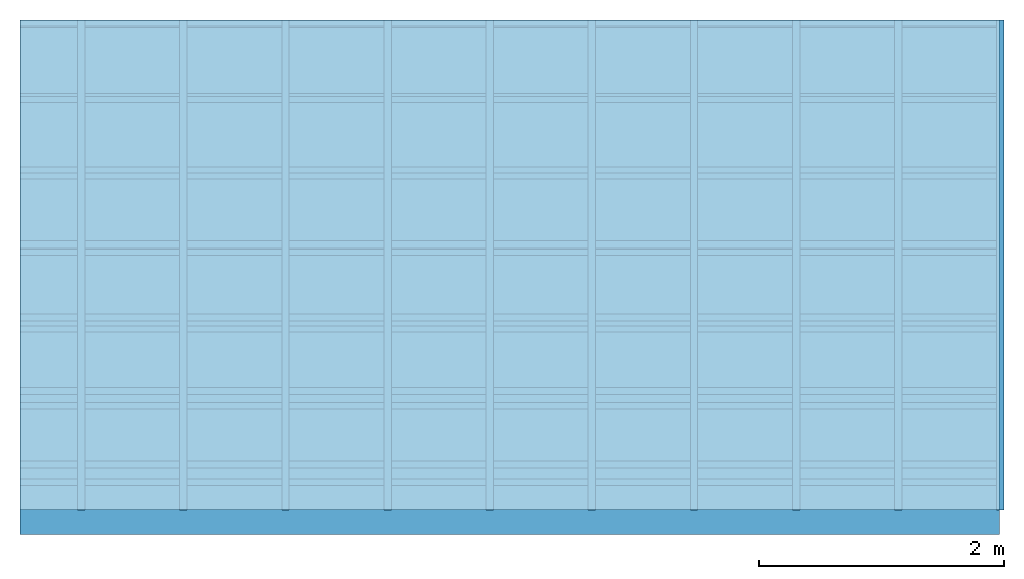
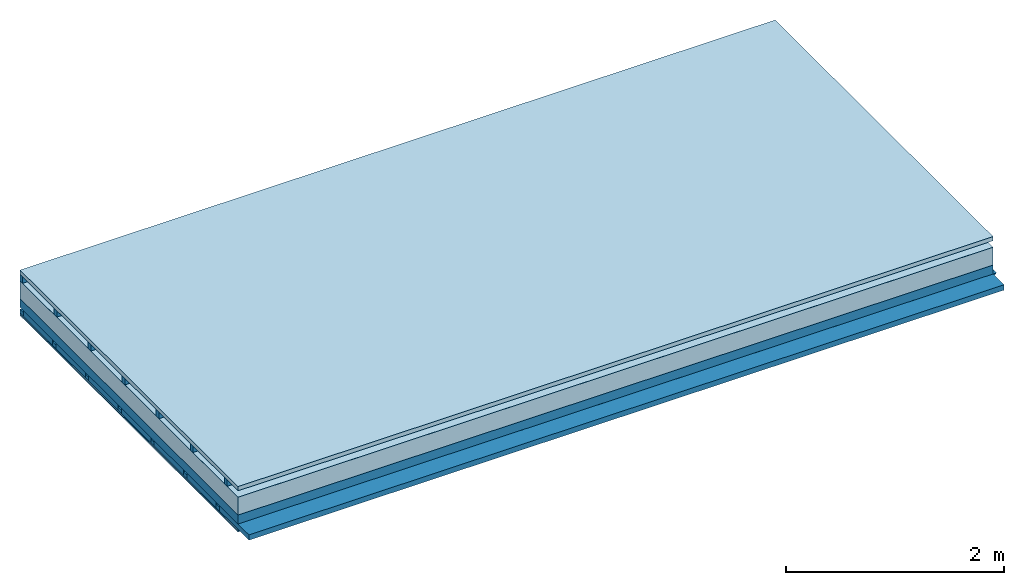
# One storey: 5 members, 5 plates, 1 element without a shape of its own.
"""IFC4 building model written with IfcOpenShell, lengths in metres."""

from ifc_helpers import new_model, si_unit, derived_unit, direction, frame, frame_2d, origin, origin_with_axes, place, context, project, spatial, polyline, rectangle, outline, extrude, material, layer, layer_set, type_object, element, aggregate, save


model = new_model("IFC4")

# Units and contexts
plan_context = context("Plan", 3, precision=1e-05, world=origin(), true_north=direction((0.0, 1.0)))
model_context = context("Model", 3, precision=1e-05, world=origin(), true_north=direction((0.0, 1.0)))
ifc_project = project(units=[si_unit("LENGTHUNIT", "METRE"), derived_unit("SOUNDPRESSUREUNIT", [(si_unit("PRESSUREUNIT", "PASCAL", prefix="MICRO"), 0)]), si_unit("ENERGYUNIT", "JOULE", prefix="MEGA"), si_unit("MASSUNIT", "GRAM", prefix="KILO"), derived_unit("THERMALTRANSMITTANCEUNIT", [(si_unit("POWERUNIT", "WATT"), 1), (si_unit("AREAUNIT", "SQUARE_METRE"), -1), (si_unit("THERMODYNAMICTEMPERATUREUNIT", "KELVIN"), -1)]), derived_unit("AREADENSITYUNIT", [(si_unit("MASSUNIT", "GRAM", prefix="KILO"), 1), (si_unit("AREAUNIT", "SQUARE_METRE"), -1)]), derived_unit("USERDEFINED", [(si_unit("ENERGYUNIT", "JOULE", prefix="MEGA"), 1), (si_unit("AREAUNIT", "SQUARE_METRE"), -1)])], contexts=[plan_context, model_context])

# Site, building, storey
site = spatial("IfcSite", under=ifc_project)
building_placement = place(None, origin())
building = spatial("IfcBuilding", under=site, at=building_placement)
storey_placement = place(building_placement, origin())
storey = spatial("IfcBuildingStorey", under=building, at=storey_placement)

# Slab, members, plates
ifc_material_1 = material(Name="Roof tiles", Category="03.015")
ifc_layer_1 = layer(ifc_material_1, 0.047, Name="Roofing")
ifc_layer_2 = layer(None, 0.072, Name="Battens / profiles")
ifc_material_2 = material(Name="Roofing underlay", Category="09.008")
ifc_layer_3 = layer(ifc_material_2, 0.00018, Name="Under the roof")
ifc_material_3 = material(Category="10.009")
ifc_layer_4 = layer(ifc_material_3, 0.2, Name="Exterior insulation layer 1")
ifc_material_4 = material(Name="no composite action")
ifc_layer_5 = layer(ifc_material_4, 0.0, Name="Bond")
ifc_layer_6 = layer(None, 0.1, Name="Supporting structure")
ifc_layer_7 = layer(ifc_material_4, 0.0, Name="Bond")
ifc_layer_8 = layer(None, 0.02, Name="Coupling")
ifc_layer_9 = layer(None, 0.04, Name="Battens / profiles")
ifc_material_5 = material(Name="Plasterboard type A", Category="03.008")
ifc_layer_10 = layer(ifc_material_5, 0.015, Name="Covering below 1st layer")
ifc_layer_11 = layer(ifc_material_5, 0.015, Name="Covering below 2nd layer")
ifc_material_6 = material(Name="joints", Category="04.017")
ifc_layer_12 = layer(ifc_material_6, 0.0, Name="Surface below")
ifc_layer_set = layer_set([ifc_layer_1, ifc_layer_2, ifc_layer_3, ifc_layer_4, ifc_layer_5, ifc_layer_6, ifc_layer_7, ifc_layer_8, ifc_layer_9, ifc_layer_10, ifc_layer_11, ifc_layer_12])
slab_type = type_object("IfcSlabType", Name="E0140", PredefinedType="NOTDEFINED", material=ifc_layer_set)
slab_placement = place(None, frame((0.0, 0.0, 0.0), z_axis=(0.0, 0.0, -1.0), x_axis=(1.0, 0.0, 0.0)))
slab = element("IfcSlab", 1, at=slab_placement, inside=storey, type_object=slab_type, material=ifc_layer_set, Name="Slab #1")
ifc_material_7 = material()
member_1_placement = place(slab_placement, origin())
member_1 = element("IfcMember", 2, at=member_1_placement, material=ifc_material_7, Name="Battens / profiles", context=plan_context, shape_type="SweptSolid", body=[
    extrude(rectangle(XDim=0.05, YDim=0.072, at=frame_2d((0.025, 0.036), x_axis=(1.0, 0.0))), frame((0.0, 0.0, 0.047), z_axis=(1.0, 0.0, 0.0), x_axis=(0.0, 1.0, 0.0)), (0.0, 0.0, 1.0), 8.0),
    extrude(rectangle(XDim=0.05, YDim=0.072, at=frame_2d((0.025, 0.036), x_axis=(1.0, 0.0))), frame((0.0, 0.625, 0.047), z_axis=(1.0, 0.0, 0.0), x_axis=(0.0, 1.0, 0.0)), (0.0, 0.0, 1.0), 8.0),
    extrude(rectangle(XDim=0.05, YDim=0.072, at=frame_2d((0.025, 0.036), x_axis=(1.0, 0.0))), frame((0.0, 1.25, 0.047), z_axis=(1.0, 0.0, 0.0), x_axis=(0.0, 1.0, 0.0)), (0.0, 0.0, 1.0), 8.0),
    extrude(rectangle(XDim=0.05, YDim=0.072, at=frame_2d((0.025, 0.036), x_axis=(1.0, 0.0))), frame((0.0, 1.875, 0.047), z_axis=(1.0, 0.0, 0.0), x_axis=(0.0, 1.0, 0.0)), (0.0, 0.0, 1.0), 8.0),
    extrude(rectangle(XDim=0.05, YDim=0.072, at=frame_2d((0.025, 0.036), x_axis=(1.0, 0.0))), frame((0.0, 2.5, 0.047), z_axis=(1.0, 0.0, 0.0), x_axis=(0.0, 1.0, 0.0)), (0.0, 0.0, 1.0), 8.0),
    extrude(rectangle(XDim=0.05, YDim=0.072, at=frame_2d((0.025, 0.036), x_axis=(1.0, 0.0))), frame((0.0, 3.125, 0.047), z_axis=(1.0, 0.0, 0.0), x_axis=(0.0, 1.0, 0.0)), (0.0, 0.0, 1.0), 8.0),
    extrude(rectangle(XDim=0.05, YDim=0.072, at=frame_2d((0.025, 0.036), x_axis=(1.0, 0.0))), frame((0.0, 3.75, 0.047), z_axis=(1.0, 0.0, 0.0), x_axis=(0.0, 1.0, 0.0)), (0.0, 0.0, 1.0), 8.0),
])
ifc_material_8 = material()
member_2_placement = place(slab_placement, origin())
member_2 = element("IfcMember", 3, at=member_2_placement, material=ifc_material_8, Name="Supporting structure", context=plan_context, shape_type="SweptSolid", body=[
    extrude(rectangle(XDim=1.0, YDim=0.1, at=frame_2d((0.5, 0.05), x_axis=(1.0, 0.0))), frame((0.0, 4.0, 0.31918), z_axis=(0.0, -1.0, 0.0), x_axis=(1.0, 0.0, 0.0)), (0.0, 0.0, 1.0), 4.0),
    extrude(rectangle(XDim=1.0, YDim=0.1, at=frame_2d((0.5, 0.05), x_axis=(1.0, 0.0))), frame((1.0, 4.0, 0.31918), z_axis=(0.0, -1.0, 0.0), x_axis=(1.0, 0.0, 0.0)), (0.0, 0.0, 1.0), 4.0),
    extrude(rectangle(XDim=1.0, YDim=0.1, at=frame_2d((0.5, 0.05), x_axis=(1.0, 0.0))), frame((2.0, 4.0, 0.31918), z_axis=(0.0, -1.0, 0.0), x_axis=(1.0, 0.0, 0.0)), (0.0, 0.0, 1.0), 4.0),
    extrude(rectangle(XDim=1.0, YDim=0.1, at=frame_2d((0.5, 0.05), x_axis=(1.0, 0.0))), frame((3.0, 4.0, 0.31918), z_axis=(0.0, -1.0, 0.0), x_axis=(1.0, 0.0, 0.0)), (0.0, 0.0, 1.0), 4.0),
    extrude(rectangle(XDim=1.0, YDim=0.1, at=frame_2d((0.5, 0.05), x_axis=(1.0, 0.0))), frame((4.0, 4.0, 0.31918), z_axis=(0.0, -1.0, 0.0), x_axis=(1.0, 0.0, 0.0)), (0.0, 0.0, 1.0), 4.0),
    extrude(rectangle(XDim=1.0, YDim=0.1, at=frame_2d((0.5, 0.05), x_axis=(1.0, 0.0))), frame((5.0, 4.0, 0.31918), z_axis=(0.0, -1.0, 0.0), x_axis=(1.0, 0.0, 0.0)), (0.0, 0.0, 1.0), 4.0),
    extrude(rectangle(XDim=1.0, YDim=0.1, at=frame_2d((0.5, 0.05), x_axis=(1.0, 0.0))), frame((6.0, 4.0, 0.31918), z_axis=(0.0, -1.0, 0.0), x_axis=(1.0, 0.0, 0.0)), (0.0, 0.0, 1.0), 4.0),
    extrude(rectangle(XDim=1.0, YDim=0.1, at=frame_2d((0.5, 0.05), x_axis=(1.0, 0.0))), frame((7.0, 4.0, 0.31918), z_axis=(0.0, -1.0, 0.0), x_axis=(1.0, 0.0, 0.0)), (0.0, 0.0, 1.0), 4.0),
])
ifc_material_9 = material()
member_3_placement = place(slab_placement, origin())
member_3 = element("IfcMember", 4, at=member_3_placement, material=ifc_material_9, Name="Coupling", context=plan_context, shape_type="SweptSolid", body=[
    extrude(outline(polyline([(0.0, 0.0), (0.06, 0.0), (0.04, 0.02), (0.02, 0.02), (0.0, 0.0)])), frame((0.47, 4.0, 0.41918), z_axis=(0.0, -1.0, 0.0), x_axis=(1.0, 0.0, 0.0)), (0.0, 0.0, 1.0), 4.0),
    extrude(outline(polyline([(0.0, 0.0), (0.06, 0.0), (0.04, 0.02), (0.02, 0.02), (0.0, 0.0)])), frame((1.304, 4.0, 0.41918), z_axis=(0.0, -1.0, 0.0), x_axis=(1.0, 0.0, 0.0)), (0.0, 0.0, 1.0), 4.0),
    extrude(outline(polyline([(0.0, 0.0), (0.06, 0.0), (0.04, 0.02), (0.02, 0.02), (0.0, 0.0)])), frame((2.138, 4.0, 0.41918), z_axis=(0.0, -1.0, 0.0), x_axis=(1.0, 0.0, 0.0)), (0.0, 0.0, 1.0), 4.0),
    extrude(outline(polyline([(0.0, 0.0), (0.06, 0.0), (0.04, 0.02), (0.02, 0.02), (0.0, 0.0)])), frame((2.972, 4.0, 0.41918), z_axis=(0.0, -1.0, 0.0), x_axis=(1.0, 0.0, 0.0)), (0.0, 0.0, 1.0), 4.0),
    extrude(outline(polyline([(0.0, 0.0), (0.06, 0.0), (0.04, 0.02), (0.02, 0.02), (0.0, 0.0)])), frame((3.806, 4.0, 0.41918), z_axis=(0.0, -1.0, 0.0), x_axis=(1.0, 0.0, 0.0)), (0.0, 0.0, 1.0), 4.0),
    extrude(outline(polyline([(0.0, 0.0), (0.06, 0.0), (0.04, 0.02), (0.02, 0.02), (0.0, 0.0)])), frame((4.64, 4.0, 0.41918), z_axis=(0.0, -1.0, 0.0), x_axis=(1.0, 0.0, 0.0)), (0.0, 0.0, 1.0), 4.0),
    extrude(outline(polyline([(0.0, 0.0), (0.06, 0.0), (0.04, 0.02), (0.02, 0.02), (0.0, 0.0)])), frame((5.474, 4.0, 0.41918), z_axis=(0.0, -1.0, 0.0), x_axis=(1.0, 0.0, 0.0)), (0.0, 0.0, 1.0), 4.0),
    extrude(outline(polyline([(0.0, 0.0), (0.06, 0.0), (0.04, 0.02), (0.02, 0.02), (0.0, 0.0)])), frame((6.308, 4.0, 0.41918), z_axis=(0.0, -1.0, 0.0), x_axis=(1.0, 0.0, 0.0)), (0.0, 0.0, 1.0), 4.0),
    extrude(outline(polyline([(0.0, 0.0), (0.06, 0.0), (0.04, 0.02), (0.02, 0.02), (0.0, 0.0)])), frame((7.142, 4.0, 0.41918), z_axis=(0.0, -1.0, 0.0), x_axis=(1.0, 0.0, 0.0)), (0.0, 0.0, 1.0), 4.0),
    extrude(outline(polyline([(0.0, 0.0), (0.06, 0.0), (0.04, 0.02), (0.02, 0.02), (0.0, 0.0)])), frame((7.976, 4.0, 0.41918), z_axis=(0.0, -1.0, 0.0), x_axis=(1.0, 0.0, 0.0)), (0.0, 0.0, 1.0), 4.0),
])
member_4_placement = place(slab_placement, origin())
member_4 = element("IfcMember", 5, at=member_4_placement, material=ifc_material_9, Name="Battens / profiles", context=plan_context, shape_type="SweptSolid", body=[
    extrude(rectangle(XDim=0.06, YDim=0.04, at=frame_2d((0.03, 0.02), x_axis=(1.0, 0.0))), frame((0.0, 0.0, 0.43918), z_axis=(1.0, 0.0, 0.0), x_axis=(0.0, 1.0, 0.0)), (0.0, 0.0, 1.0), 8.0),
    extrude(rectangle(XDim=0.06, YDim=0.04, at=frame_2d((0.03, 0.02), x_axis=(1.0, 0.0))), frame((0.0, 0.6, 0.43918), z_axis=(1.0, 0.0, 0.0), x_axis=(0.0, 1.0, 0.0)), (0.0, 0.0, 1.0), 8.0),
    extrude(rectangle(XDim=0.06, YDim=0.04, at=frame_2d((0.03, 0.02), x_axis=(1.0, 0.0))), frame((0.0, 1.2, 0.43918), z_axis=(1.0, 0.0, 0.0), x_axis=(0.0, 1.0, 0.0)), (0.0, 0.0, 1.0), 8.0),
    extrude(rectangle(XDim=0.06, YDim=0.04, at=frame_2d((0.03, 0.02), x_axis=(1.0, 0.0))), frame((0.0, 1.8, 0.43918), z_axis=(1.0, 0.0, 0.0), x_axis=(0.0, 1.0, 0.0)), (0.0, 0.0, 1.0), 8.0),
    extrude(rectangle(XDim=0.06, YDim=0.04, at=frame_2d((0.03, 0.02), x_axis=(1.0, 0.0))), frame((0.0, 2.4, 0.43918), z_axis=(1.0, 0.0, 0.0), x_axis=(0.0, 1.0, 0.0)), (0.0, 0.0, 1.0), 8.0),
    extrude(rectangle(XDim=0.06, YDim=0.04, at=frame_2d((0.03, 0.02), x_axis=(1.0, 0.0))), frame((0.0, 3.0, 0.43918), z_axis=(1.0, 0.0, 0.0), x_axis=(0.0, 1.0, 0.0)), (0.0, 0.0, 1.0), 8.0),
    extrude(rectangle(XDim=0.06, YDim=0.04, at=frame_2d((0.03, 0.02), x_axis=(1.0, 0.0))), frame((0.0, 3.6, 0.43918), z_axis=(1.0, 0.0, 0.0), x_axis=(0.0, 1.0, 0.0)), (0.0, 0.0, 1.0), 8.0),
])
ifc_material_10 = material(Name="Mineral wool")
member_5_placement = place(slab_placement, origin())
member_5 = element("IfcMember", 6, at=member_5_placement, material=ifc_material_10, Name="Cavity", context=plan_context, shape_type="SweptSolid", body=[
    extrude(rectangle(XDim=0.54, YDim=0.06, at=frame_2d((0.27, 0.03), x_axis=(1.0, 0.0))), frame((0.0, 0.06, 0.41918), z_axis=(1.0, 0.0, 0.0), x_axis=(0.0, 1.0, 0.0)), (0.0, 0.0, 1.0), 8.0),
    extrude(rectangle(XDim=0.54, YDim=0.06, at=frame_2d((0.27, 0.03), x_axis=(1.0, 0.0))), frame((0.0, 0.66, 0.41918), z_axis=(1.0, 0.0, 0.0), x_axis=(0.0, 1.0, 0.0)), (0.0, 0.0, 1.0), 8.0),
    extrude(rectangle(XDim=0.54, YDim=0.06, at=frame_2d((0.27, 0.03), x_axis=(1.0, 0.0))), frame((0.0, 1.26, 0.41918), z_axis=(1.0, 0.0, 0.0), x_axis=(0.0, 1.0, 0.0)), (0.0, 0.0, 1.0), 8.0),
    extrude(rectangle(XDim=0.54, YDim=0.06, at=frame_2d((0.27, 0.03), x_axis=(1.0, 0.0))), frame((0.0, 1.86, 0.41918), z_axis=(1.0, 0.0, 0.0), x_axis=(0.0, 1.0, 0.0)), (0.0, 0.0, 1.0), 8.0),
    extrude(rectangle(XDim=0.54, YDim=0.06, at=frame_2d((0.27, 0.03), x_axis=(1.0, 0.0))), frame((0.0, 2.46, 0.41918), z_axis=(1.0, 0.0, 0.0), x_axis=(0.0, 1.0, 0.0)), (0.0, 0.0, 1.0), 8.0),
    extrude(rectangle(XDim=0.54, YDim=0.06, at=frame_2d((0.27, 0.03), x_axis=(1.0, 0.0))), frame((0.0, 3.06, 0.41918), z_axis=(1.0, 0.0, 0.0), x_axis=(0.0, 1.0, 0.0)), (0.0, 0.0, 1.0), 8.0),
    extrude(rectangle(XDim=0.54, YDim=0.06, at=frame_2d((0.27, 0.03), x_axis=(1.0, 0.0))), frame((0.0, 3.66, 0.41918), z_axis=(1.0, 0.0, 0.0), x_axis=(0.0, 1.0, 0.0)), (0.0, 0.0, 1.0), 8.0),
])
plate_1_placement = place(slab_placement, origin())
plate_1 = element("IfcPlate", 7, at=plate_1_placement, material=ifc_material_1, Name="Roofing", context=plan_context, shape_type="SweptSolid", body=[
    extrude(rectangle(XDim=8.0, YDim=4.0, at=frame_2d((4.0, 2.0), x_axis=(1.0, 0.0))), origin_with_axes(), (0.0, 0.0, 1.0), 0.047),
])
plate_2_placement = place(slab_placement, origin())
plate_2 = element("IfcPlate", 8, at=plate_2_placement, material=ifc_material_2, Name="Under the roof", context=plan_context, shape_type="SweptSolid", body=[
    extrude(rectangle(XDim=8.0, YDim=4.0, at=frame_2d((4.0, 2.0), x_axis=(1.0, 0.0))), frame((0.0, 0.0, 0.119), z_axis=(0.0, 0.0, 1.0), x_axis=(1.0, 0.0, 0.0)), (0.0, 0.0, 1.0), 0.00018),
])
plate_3_placement = place(slab_placement, origin())
plate_3 = element("IfcPlate", 9, at=plate_3_placement, material=ifc_material_3, Name="Exterior insulation layer 1", context=plan_context, shape_type="SweptSolid", body=[
    extrude(rectangle(XDim=8.0, YDim=4.0, at=frame_2d((4.0, 2.0), x_axis=(1.0, 0.0))), frame((0.0, 0.0, 0.11918), z_axis=(0.0, 0.0, 1.0), x_axis=(1.0, 0.0, 0.0)), (0.0, 0.0, 1.0), 0.2),
])
plate_4_placement = place(slab_placement, origin())
plate_4 = element("IfcPlate", 10, at=plate_4_placement, material=ifc_material_5, Name="Covering below 1st layer", context=plan_context, shape_type="SweptSolid", body=[
    extrude(rectangle(XDim=8.0, YDim=4.0, at=frame_2d((4.0, 2.0), x_axis=(1.0, 0.0))), frame((0.0, 0.0, 0.47918), z_axis=(0.0, 0.0, 1.0), x_axis=(1.0, 0.0, 0.0)), (0.0, 0.0, 1.0), 0.015),
])
plate_5_placement = place(slab_placement, origin())
plate_5 = element("IfcPlate", 11, at=plate_5_placement, material=ifc_material_5, Name="Covering below 2nd layer", context=plan_context, shape_type="SweptSolid", body=[
    extrude(rectangle(XDim=8.0, YDim=4.0, at=frame_2d((4.0, 2.0), x_axis=(1.0, 0.0))), frame((0.0, 0.0, 0.49418), z_axis=(0.0, 0.0, 1.0), x_axis=(1.0, 0.0, 0.0)), (0.0, 0.0, 1.0), 0.015),
])
aggregate(slab, [plate_1, member_1, plate_2, plate_3, member_2, member_3, member_4, member_5, plate_4, plate_5])

save(model, "model.ifc")
